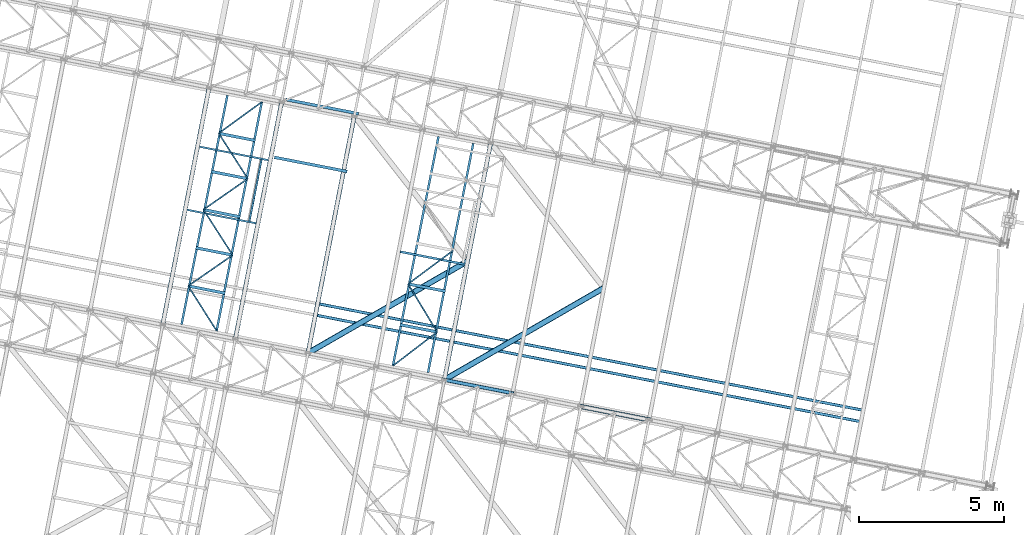
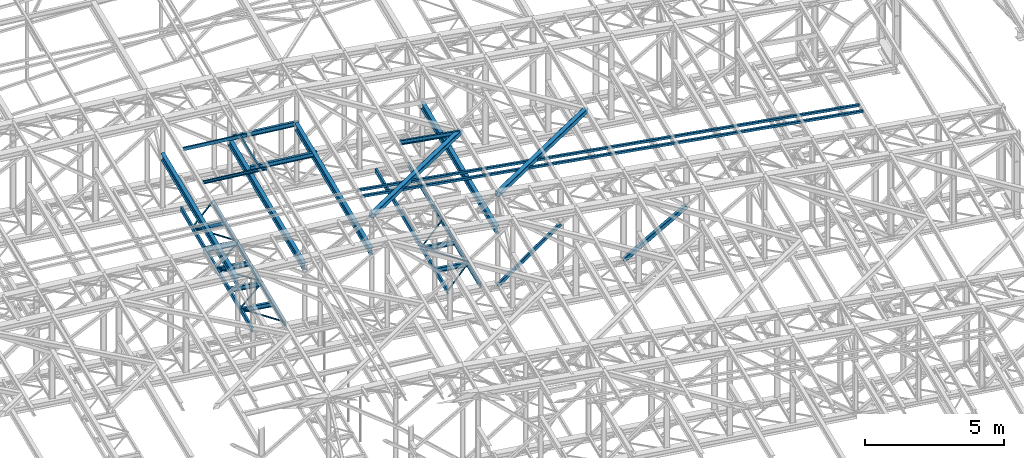
# One storey, part 90 of 215: 34 beams, 2 members, 36 elements without a shape of their own.
"""IFC2X3 building model written with IfcOpenShell, lengths in millimetres."""

from ifc_helpers import new_model, si_unit, frame, origin_with_axes, origin_2d_with_axis, place, context, subcontext, project, spatial, hollow_rectangle, i_section, u_section, extrude, material, type_object, element, aggregate, save


model = new_model("IFC2X3")

# Units and contexts
model_context = context("Model", 3, precision=1e-05, world=origin_with_axes())
body_context = subcontext(model_context, "Body", "Model", "MODEL_VIEW")
ifc_project = project(units=[si_unit("LENGTHUNIT", "METRE", prefix="MILLI"), si_unit("AREAUNIT", "SQUARE_METRE"), si_unit("VOLUMEUNIT", "CUBIC_METRE"), si_unit("MASSUNIT", "GRAM", prefix="KILO"), si_unit("TIMEUNIT", "SECOND"), si_unit("PLANEANGLEUNIT", "RADIAN"), si_unit("SOLIDANGLEUNIT", "STERADIAN"), si_unit("THERMODYNAMICTEMPERATUREUNIT", "DEGREE_CELSIUS"), si_unit("LUMINOUSINTENSITYUNIT", "LUMEN")], contexts=[model_context])

# Site, building, storey
site_placement = place(None, origin_with_axes())
site = spatial("IfcSite", under=ifc_project, at=site_placement, CompositionType="ELEMENT")
building_placement = place(site_placement, origin_with_axes())
building = spatial("IfcBuilding", under=site, at=building_placement, Name="Undefined", CompositionType="ELEMENT")
storey_placement = place(building_placement, origin_with_axes())
storey = spatial("IfcBuildingStorey", under=building, at=storey_placement, Name="Undefined", CompositionType="ELEMENT", Elevation=0.0)

# Assembly, beam
assembly_1_placement = place(storey_placement, origin_with_axes())
assembly_1 = element("IfcElementAssembly", 1, at=assembly_1_placement, inside=storey, Name="Steel Assembly", AssemblyPlace="NOTDEFINED", PredefinedType="RIGID_FRAME")
ifc_material_1 = material(Name="STEEL/S275JR")
beam_type_1 = type_object("IfcBeamType", PredefinedType="NOTDEFINED")
beam_1_placement = place(assembly_1_placement, frame((71760.0971144272, 40485.748409358, 12727.980944659), z_axis=(-0.0304080339975108, 0.00594450399951394, -0.999519891918418), x_axis=(0.980943076639626, -0.191809005929534, -0.0309836349886174)))
beam_1 = element("IfcBeam", 2, at=beam_1_placement, type_object=beam_type_1, material=ifc_material_1, context=body_context, shape_type="SweptSolid", body=[
    extrude(hollow_rectangle(XDim=100.0, YDim=100.0, WallThickness=5.0, InnerFilletRadius=5.0, OuterFilletRadius=10.0, at=origin_2d_with_axis()), frame((19054.6230953848, 6.46745726067925e-12, -1.32218008037815e-13), z_axis=(-1.0, 0.0, 0.0), x_axis=(-6.93889390390723e-18, -1.0, -3.46944695195361e-18)), (0.0, 0.0, 1.0), 19054.6),
])
aggregate(assembly_1, [beam_1])

assembly_2_placement = place(storey_placement, origin_with_axes())
assembly_2 = element("IfcElementAssembly", 3, at=assembly_2_placement, inside=storey, Name="Steel Assembly", AssemblyPlace="NOTDEFINED", PredefinedType="RIGID_FRAME")
beam_2_placement = place(assembly_2_placement, frame((71683.3366470198, 40093.1827070397, 12727.9809445481), z_axis=(-0.0304080339975108, 0.00594450399951394, -0.999519891918418), x_axis=(0.980943076639626, -0.191809005929534, -0.0309836349886174)))
beam_2 = element("IfcBeam", 4, at=beam_2_placement, type_object=beam_type_1, material=ifc_material_1, context=body_context, shape_type="SweptSolid", body=[
    extrude(hollow_rectangle(XDim=100.0, YDim=100.0, WallThickness=5.0, InnerFilletRadius=5.0, OuterFilletRadius=10.0, at=origin_2d_with_axis()), frame((19054.6230953848, 6.46745726067925e-12, -1.32218008037815e-13), z_axis=(-1.0, 0.0, 0.0), x_axis=(-6.93889390390723e-18, -1.0, -3.46944695195361e-18)), (0.0, 0.0, 1.0), 19054.6),
])
aggregate(assembly_2, [beam_2])

assembly_3_placement = place(storey_placement, origin_with_axes())
assembly_3 = element("IfcElementAssembly", 5, at=assembly_3_placement, inside=storey, Name="Steel Assembly", AssemblyPlace="NOTDEFINED", PredefinedType="RIGID_FRAME")
beam_type_2 = type_object("IfcBeamType", PredefinedType="NOTDEFINED")
beam_3_placement = place(assembly_3_placement, frame((75811.4755833182, 39522.2912001159, 8745.0), z_axis=(0.0, 0.0, -1.0), x_axis=(-0.79408618805292, -0.607805171040509, 0.0)))
beam_3 = element("IfcBeam", 6, at=beam_3_placement, type_object=beam_type_2, material=ifc_material_1, context=body_context, shape_type="SweptSolid", body=[
    extrude(hollow_rectangle(XDim=50.0, YDim=50.0, WallThickness=3.0, InnerFilletRadius=3.0, OuterFilletRadius=6.0, at=origin_2d_with_axis()), frame((1907.07835374003, -1.05864114904321e-13, 0.0), z_axis=(-1.0, 0.0, 0.0), x_axis=(-6.93889390390723e-18, -1.0, -3.46944695195361e-18)), (0.0, 0.0, 1.0), 1907.1),
])
aggregate(assembly_3, [beam_3])

assembly_4_placement = place(storey_placement, origin_with_axes())
assembly_4 = element("IfcElementAssembly", 7, at=assembly_4_placement, inside=storey, Name="Steel Assembly", AssemblyPlace="NOTDEFINED", PredefinedType="RIGID_FRAME")
beam_4_placement = place(assembly_4_placement, frame((67254.4397263109, 41103.1133654688, 8745.0), z_axis=(0.0, 0.0, -1.0), x_axis=(0.535514965031223, -0.844525738049237, 0.0)))
beam_4 = element("IfcBeam", 8, at=beam_4_placement, type_object=beam_type_2, material=ifc_material_1, context=body_context, shape_type="SweptSolid", body=[
    extrude(hollow_rectangle(XDim=50.0, YDim=50.0, WallThickness=3.0, InnerFilletRadius=3.0, OuterFilletRadius=6.0, at=origin_2d_with_axis()), frame((1826.34846929784, 0.0, 0.0), z_axis=(-1.0, 0.0, 0.0), x_axis=(-6.93889390390723e-18, -1.0, -3.46944695195361e-18)), (0.0, 0.0, 1.0), 1826.3),
])
aggregate(assembly_4, [beam_4])

assembly_5_placement = place(storey_placement, origin_with_axes())
assembly_5 = element("IfcElementAssembly", 9, at=assembly_5_placement, inside=storey, Name="Steel Assembly", AssemblyPlace="NOTDEFINED", PredefinedType="RIGID_FRAME")
beam_5_placement = place(assembly_5_placement, frame((68784.1157093608, 42163.947772799, 8745.0), z_axis=(0.0, 0.0, -1.0), x_axis=(-0.82173236308309, -0.569873603057627, 0.0)))
beam_5 = element("IfcBeam", 10, at=beam_5_placement, type_object=beam_type_2, material=ifc_material_1, context=body_context, shape_type="SweptSolid", body=[
    extrude(hollow_rectangle(XDim=50.0, YDim=50.0, WallThickness=3.0, InnerFilletRadius=3.0, OuterFilletRadius=6.0, at=origin_2d_with_axis()), frame((1861.52578629915, -9.09494701772928e-13, 1.81898940354586e-12), z_axis=(-1.0, 0.0, 0.0), x_axis=(-6.93889390390723e-18, -1.0, -3.46944695195361e-18)), (0.0, 0.0, 1.0), 1861.5),
])
aggregate(assembly_5, [beam_5])

assembly_6_placement = place(storey_placement, origin_with_axes())
assembly_6 = element("IfcElementAssembly", 11, at=assembly_6_placement, inside=storey, Name="Steel Assembly", AssemblyPlace="NOTDEFINED", PredefinedType="RIGID_FRAME")
beam_6_placement = place(assembly_6_placement, frame((67779.1252784638, 43726.6375422795, 8745.0), z_axis=(0.0, 0.0, -1.0), x_axis=(0.540911498210623, -0.841079515327498, 0.0)))
beam_6 = element("IfcBeam", 12, at=beam_6_placement, type_object=beam_type_2, material=ifc_material_1, context=body_context, shape_type="SweptSolid", body=[
    extrude(hollow_rectangle(XDim=50.0, YDim=50.0, WallThickness=3.0, InnerFilletRadius=3.0, OuterFilletRadius=6.0, at=origin_2d_with_axis()), frame((1857.95723370648, -1.0313734498149e-13, 0.0), z_axis=(-1.0, 0.0, 0.0), x_axis=(-6.93889390390723e-18, -1.0, -3.46944695195361e-18)), (0.0, 0.0, 1.0), 1858.0),
])
aggregate(assembly_6, [beam_6])

assembly_7_placement = place(storey_placement, origin_with_axes())
assembly_7 = element("IfcElementAssembly", 13, at=assembly_7_placement, inside=storey, Name="Steel Assembly", AssemblyPlace="NOTDEFINED", PredefinedType="RIGID_FRAME")
beam_7_placement = place(assembly_7_placement, frame((69303.2921745748, 44788.5637698826, 8745.0), z_axis=(0.0, 0.0, -1.0), x_axis=(-0.820492073033562, -0.57165790302338, 0.0)))
beam_7 = element("IfcBeam", 14, at=beam_7_placement, type_object=beam_type_2, material=ifc_material_1, context=body_context, shape_type="SweptSolid", body=[
    extrude(hollow_rectangle(XDim=50.0, YDim=50.0, WallThickness=3.0, InnerFilletRadius=3.0, OuterFilletRadius=6.0, at=origin_2d_with_axis()), frame((1857.62537670751, -1.03118923217433e-13, 0.0), z_axis=(-1.0, 0.0, 0.0), x_axis=(-6.93889390390723e-18, -1.0, -3.46944695195361e-18)), (0.0, 0.0, 1.0), 1857.6),
])
aggregate(assembly_7, [beam_7])

assembly_8_placement = place(storey_placement, origin_with_axes())
assembly_8 = element("IfcElementAssembly", 15, at=assembly_8_placement, inside=storey, Name="Steel Assembly", AssemblyPlace="NOTDEFINED", PredefinedType="RIGID_FRAME")
beam_8_placement = place(assembly_8_placement, frame((68303.8108306167, 46350.1617190901, 8745.0), z_axis=(0.0, 0.0, -1.0), x_axis=(0.539076140159352, -0.842257036248968, 0.0)))
beam_8 = element("IfcBeam", 16, at=beam_8_placement, type_object=beam_type_2, material=ifc_material_1, context=body_context, shape_type="SweptSolid", body=[
    extrude(hollow_rectangle(XDim=50.0, YDim=50.0, WallThickness=3.0, InnerFilletRadius=3.0, OuterFilletRadius=6.0, at=origin_2d_with_axis()), frame((1854.06340553235, 0.0, 0.0), z_axis=(-1.0, 0.0, 0.0), x_axis=(-6.93889390390723e-18, -1.0, -3.46944695195361e-18)), (0.0, 0.0, 1.0), 1854.1),
])
aggregate(assembly_8, [beam_8])

assembly_9_placement = place(storey_placement, origin_with_axes())
assembly_9 = element("IfcElementAssembly", 17, at=assembly_9_placement, inside=storey, Name="Steel Assembly", AssemblyPlace="NOTDEFINED", PredefinedType="RIGID_FRAME")
beam_9_placement = place(assembly_9_placement, frame((69782.1158846942, 47424.3089371193, 8745.0), z_axis=(0.0, 0.0, -1.0), x_axis=(-0.808992082681723, -0.587819538768735, 0.0)))
beam_9 = element("IfcBeam", 18, at=beam_9_placement, type_object=beam_type_2, material=ifc_material_1, context=body_context, shape_type="SweptSolid", body=[
    extrude(hollow_rectangle(XDim=50.0, YDim=50.0, WallThickness=3.0, InnerFilletRadius=3.0, OuterFilletRadius=6.0, at=origin_2d_with_axis()), frame((1827.34180674125, 0.0, 0.0), z_axis=(-1.0, 0.0, 0.0), x_axis=(-6.93889390390723e-18, -1.0, -3.46944695195361e-18)), (0.0, 0.0, 1.0), 1827.3),
])
aggregate(assembly_9, [beam_9])

assembly_10_placement = place(storey_placement, origin_with_axes())
assembly_10 = element("IfcElementAssembly", 19, at=assembly_10_placement, inside=storey, Name="Steel Assembly", AssemblyPlace="NOTDEFINED", PredefinedType="RIGID_FRAME")
beam_10_placement = place(assembly_10_placement, frame((74812.6471326999, 41172.5850104912, 8745.0), z_axis=(0.0, 0.0, -1.0), x_axis=(0.517808927242957, -0.855496297401396, 0.0)))
beam_10 = element("IfcBeam", 20, at=beam_10_placement, type_object=beam_type_2, material=ifc_material_1, context=body_context, shape_type="SweptSolid", body=[
    extrude(hollow_rectangle(XDim=50.0, YDim=50.0, WallThickness=3.0, InnerFilletRadius=3.0, OuterFilletRadius=6.0, at=origin_2d_with_axis()), frame((1929.07382191218, 0.0, 0.0), z_axis=(-1.0, 0.0, 0.0), x_axis=(-6.93889390390723e-18, -1.0, -3.46944695195361e-18)), (0.0, 0.0, 1.0), 1929.1),
])
aggregate(assembly_10, [beam_10])

assembly_11_placement = place(storey_placement, origin_with_axes())
assembly_11 = element("IfcElementAssembly", 21, at=assembly_11_placement, inside=storey, Name="Steel Assembly", AssemblyPlace="NOTDEFINED", PredefinedType="RIGID_FRAME")
beam_11_placement = place(assembly_11_placement, frame((76365.2607052692, 42324.1190063825, 8745.0), z_axis=(0.0, 0.0, -1.0), x_axis=(-0.803198301073351, -0.595711750054406, 0.0)))
beam_11 = element("IfcBeam", 22, at=beam_11_placement, type_object=beam_type_2, material=ifc_material_1, context=body_context, shape_type="SweptSolid", body=[
    extrude(hollow_rectangle(XDim=50.0, YDim=50.0, WallThickness=3.0, InnerFilletRadius=3.0, OuterFilletRadius=6.0, at=origin_2d_with_axis()), frame((1933.03891586361, -2.14610431188823e-13, 0.0), z_axis=(-1.0, 0.0, 0.0), x_axis=(-6.93889390390723e-18, -1.0, -3.46944695195361e-18)), (0.0, 0.0, 1.0), 1933.0),
])
aggregate(assembly_11, [beam_11])

assembly_12_placement = place(storey_placement, origin_with_axes())
assembly_12 = element("IfcElementAssembly", 23, at=assembly_12_placement, inside=storey, Name="Steel Assembly", AssemblyPlace="NOTDEFINED", PredefinedType="RIGID_FRAME")
ifc_material_2 = material(Name="STEEL/S235JR")
beam_type_3 = type_object("IfcBeamType", Name="UPN140", PredefinedType="NOTDEFINED")
beam_12_placement = place(assembly_12_placement, frame((69359.8557503817, 43332.3585434962, 12761.5566364276), z_axis=(-0.0304080349967745, 0.00594450299936818, 0.999519891893966), x_axis=(0.191880718074391, 0.981418254380493, 4.40000000352173e-08)))
beam_12 = element("IfcBeam", 24, at=beam_12_placement, type_object=beam_type_3, material=ifc_material_2, ObjectType="UPN140", context=body_context, shape_type="SweptSolid", body=[
    extrude(u_section(Depth=140.0, FlangeWidth=60.0, WebThickness=7.0, FlangeThickness=10.0, FilletRadius=10.0, EdgeRadius=5.0, FlangeSlope=0.0798299857122373, at=origin_2d_with_axis()), frame((2149.99964798419, 2.35154323650116e-15, 1.8176342764527e-12), z_axis=(-1.0, 0.0, 0.0), x_axis=(-6.93889390390723e-18, -1.0, -3.46944695195361e-18)), (0.0, 0.0, 1.0), 2150.0),
])
aggregate(assembly_12, [beam_12])

assembly_13_placement = place(storey_placement, origin_with_axes())
assembly_13 = element("IfcElementAssembly", 25, at=assembly_13_placement, inside=storey, Name="Steel Assembly", AssemblyPlace="NOTDEFINED", PredefinedType="RIGID_FRAME")
beam_13_placement = place(assembly_13_placement, frame((70018.1932395436, 45424.9236830966, 12769.1384012091), z_axis=(-0.0304080349967745, 0.00594450299936818, 0.999519891893966), x_axis=(-0.980947279001733, 0.191787511000338, -0.0309836480000548)))
beam_13 = element("IfcBeam", 26, at=beam_13_placement, type_object=beam_type_3, material=ifc_material_2, ObjectType="UPN140", context=body_context, shape_type="SweptSolid", body=[
    extrude(u_section(Depth=140.0, FlangeWidth=60.0, WebThickness=7.0, FlangeThickness=10.0, FilletRadius=10.0, EdgeRadius=5.0, FlangeSlope=0.0798299857122373, at=origin_2d_with_axis()), frame((2424.69780127148, -3.7379625959944e-14, 0.0), z_axis=(-1.0, 0.0, 0.0), x_axis=(-6.93889390390723e-18, -1.0, -3.46944695195361e-18)), (0.0, 0.0, 1.0), 2424.7),
])
aggregate(assembly_13, [beam_13])

assembly_14_placement = place(storey_placement, origin_with_axes())
assembly_14 = element("IfcElementAssembly", 27, at=assembly_14_placement, inside=storey, Name="Steel Assembly", AssemblyPlace="NOTDEFINED", PredefinedType="RIGID_FRAME")
beam_14_placement = place(assembly_14_placement, frame((67215.6361783717, 43721.015713209, 12694.0123238782), z_axis=(-0.0304080349967745, 0.00594450299936818, 0.999519891893966), x_axis=(0.9809472788136, -0.191787511963556, 0.0309836479941128)))
beam_14 = element("IfcBeam", 28, at=beam_14_placement, type_object=beam_type_3, material=ifc_material_2, ObjectType="UPN140", context=body_context, shape_type="SweptSolid", body=[
    extrude(u_section(Depth=140.0, FlangeWidth=60.0, WebThickness=7.0, FlangeThickness=10.0, FilletRadius=10.0, EdgeRadius=5.0, FlangeSlope=0.0798299857122373, at=origin_2d_with_axis()), frame((2424.69780127148, -3.7379625959944e-14, 0.0), z_axis=(-1.0, 0.0, 0.0), x_axis=(-6.93889390390723e-18, -1.0, -3.46944695195361e-18)), (0.0, 0.0, 1.0), 2424.7),
])
aggregate(assembly_14, [beam_14])

assembly_15_placement = place(storey_placement, origin_with_axes())
assembly_15 = element("IfcElementAssembly", 29, at=assembly_15_placement, inside=storey, Name="Steel Assembly", AssemblyPlace="NOTDEFINED", PredefinedType="RIGID_FRAME")
beam_type_4 = type_object("IfcBeamType", Name="UPN200", PredefinedType="NOTDEFINED")
beam_15_placement = place(assembly_15_placement, frame((74545.5207751963, 42280.4389818279, 12743.959350756), z_axis=(0.0304080349965938, -0.00594450399933318, 0.999519891888024), x_axis=(0.980947274706054, -0.191787533942531, -0.0309836419907153)))
beam_15 = element("IfcBeam", 30, at=beam_15_placement, type_object=beam_type_4, material=ifc_material_2, ObjectType="UPN200", context=body_context, shape_type="SweptSolid", body=[
    extrude(u_section(Depth=200.0, FlangeWidth=75.0, WebThickness=8.5, FlangeThickness=11.5, FilletRadius=11.5, EdgeRadius=6.0, FlangeSlope=0.0798299857122373, at=origin_2d_with_axis()), frame((2269.56619159897, -1.00164711038344e-14, -7.87413950570001e-15), z_axis=(-1.0, 0.0, 0.0), x_axis=(-6.93889390390723e-18, -1.0, -3.46944695195361e-18)), (0.0, 0.0, 1.0), 2269.6),
])
aggregate(assembly_15, [beam_15])

assembly_16_placement = place(storey_placement, origin_with_axes())
assembly_16 = element("IfcElementAssembly", 31, at=assembly_16_placement, inside=storey, Name="Steel Assembly", AssemblyPlace="NOTDEFINED", PredefinedType="RIGID_FRAME")
beam_16_placement = place(assembly_16_placement, frame((68602.925434007, 47654.5697123101, 8670.00000003361), z_axis=(0.0, 0.0, -1.0), x_axis=(-0.196109204940981, -0.980582061704892, 0.0)))
beam_16 = element("IfcBeam", 32, at=beam_16_placement, type_object=beam_type_4, material=ifc_material_1, ObjectType="UPN200", context=body_context, shape_type="SweptSolid", body=[
    extrude(u_section(Depth=200.0, FlangeWidth=75.0, WebThickness=8.5, FlangeThickness=11.5, FilletRadius=11.5, EdgeRadius=6.0, FlangeSlope=0.0798299857122373, at=origin_2d_with_axis()), frame((8026.42923811888, 0.0, 1.81898940354586e-12), z_axis=(-1.0, 0.0, 0.0), x_axis=(-6.93889390390723e-18, -1.0, -3.46944695195361e-18)), (0.0, 0.0, 1.0), 8026.4),
])
aggregate(assembly_16, [beam_16])

assembly_17_placement = place(storey_placement, origin_with_axes())
assembly_17 = element("IfcElementAssembly", 33, at=assembly_17_placement, inside=storey, Name="Steel Assembly", AssemblyPlace="NOTDEFINED", PredefinedType="RIGID_FRAME")
beam_17_placement = place(assembly_17_placement, frame((68228.7504539045, 39549.6817770893, 8670.00000000005), z_axis=(0.0, 0.0, -1.0), x_axis=(0.194052090085154, 0.980991226430483, 0.0)))
beam_17 = element("IfcBeam", 34, at=beam_17_placement, type_object=beam_type_4, material=ifc_material_1, ObjectType="UPN200", context=body_context, shape_type="SweptSolid", body=[
    extrude(u_section(Depth=200.0, FlangeWidth=75.0, WebThickness=8.5, FlangeThickness=11.5, FilletRadius=11.5, EdgeRadius=6.0, FlangeSlope=0.0798299857122373, at=origin_2d_with_axis()), frame((8026.37396392401, 4.45553258950016e-13, 0.0), z_axis=(-1.0, 0.0, 0.0), x_axis=(-6.93889390390723e-18, -1.0, -3.46944695195361e-18)), (0.0, 0.0, 1.0), 8026.4),
])
aggregate(assembly_17, [beam_17])

assembly_18_placement = place(storey_placement, origin_with_axes())
assembly_18 = element("IfcElementAssembly", 35, at=assembly_18_placement, inside=storey, Name="Steel Assembly", AssemblyPlace="NOTDEFINED", PredefinedType="RIGID_FRAME")
beam_18_placement = place(assembly_18_placement, frame((75856.9384994889, 46236.522651763, 8670.00000003361), z_axis=(0.0, 0.0, -1.0), x_axis=(-0.194859176941111, -0.980831229703578, 0.0)))
beam_18 = element("IfcBeam", 36, at=beam_18_placement, type_object=beam_type_4, material=ifc_material_1, ObjectType="UPN200", context=body_context, shape_type="SweptSolid", body=[
    extrude(u_section(Depth=200.0, FlangeWidth=75.0, WebThickness=8.5, FlangeThickness=11.5, FilletRadius=11.5, EdgeRadius=6.0, FlangeSlope=0.0798299857122373, at=origin_2d_with_axis()), frame((8026.39143846781, 0.0, 0.0), z_axis=(-1.0, 0.0, 0.0), x_axis=(-6.93889390390723e-18, -1.0, -3.46944695195361e-18)), (0.0, 0.0, 1.0), 8026.4),
])
aggregate(assembly_18, [beam_18])

assembly_19_placement = place(storey_placement, origin_with_axes())
assembly_19 = element("IfcElementAssembly", 37, at=assembly_19_placement, inside=storey, Name="Steel Assembly", AssemblyPlace="NOTDEFINED", PredefinedType="RIGID_FRAME")
beam_19_placement = place(assembly_19_placement, frame((75498.090298128, 38128.5774915551, 8670.00000000005), z_axis=(0.0, 0.0, -1.0), x_axis=(0.193737014918304, 0.981053499586309, 0.0)))
beam_19 = element("IfcBeam", 38, at=beam_19_placement, type_object=beam_type_4, material=ifc_material_1, ObjectType="UPN200", context=body_context, shape_type="SweptSolid", body=[
    extrude(u_section(Depth=200.0, FlangeWidth=75.0, WebThickness=8.5, FlangeThickness=11.5, FilletRadius=11.5, EdgeRadius=6.0, FlangeSlope=0.0798299857122373, at=origin_2d_with_axis()), frame((8026.36861737095, 2.2277648107835e-13, 0.0), z_axis=(-1.0, 0.0, 0.0), x_axis=(-6.93889390390723e-18, -1.0, -3.46944695195361e-18)), (0.0, 0.0, 1.0), 8026.4),
])
aggregate(assembly_19, [beam_19])

# Assembly, member
assembly_20_placement = place(storey_placement, origin_with_axes())
assembly_20 = element("IfcElementAssembly", 39, at=assembly_20_placement, inside=storey, Name="Steel Assembly", AssemblyPlace="NOTDEFINED", PredefinedType="RIGID_FRAME")
member_type_1 = type_object("IfcMemberType", PredefinedType="NOTDEFINED")
member_1_placement = place(assembly_20_placement, frame((76059.9648931922, 37875.3654009255, 8635.00000002286), z_axis=(0.658795867060445, -0.12879937101182, -0.741214360068014), x_axis=(0.727444441074387, -0.142208697014541, 0.671268405068643)))
member_1 = element("IfcMember", 40, at=member_1_placement, type_object=member_type_1, material=ifc_material_1, context=body_context, shape_type="SweptSolid", body=[
    extrude(hollow_rectangle(XDim=120.0, YDim=120.0, WallThickness=5.0, InnerFilletRadius=5.0, OuterFilletRadius=10.0, at=origin_2d_with_axis()), frame((3220.54913749736, 7.11337137710058e-12, -7.63351039462205e-12), z_axis=(-1.0, 0.0, 0.0), x_axis=(-6.93889390390723e-18, -1.0, -3.46944695195361e-18)), (0.0, 0.0, 1.0), 3220.5),
])
aggregate(assembly_20, [member_1])

# Assembly, beam
assembly_21_placement = place(storey_placement, origin_with_axes())
assembly_21 = element("IfcElementAssembly", 41, at=assembly_21_placement, inside=storey, Name="Steel Assembly", AssemblyPlace="NOTDEFINED", PredefinedType="RIGID_FRAME")
beam_type_5 = type_object("IfcBeamType", PredefinedType="NOTDEFINED")
beam_20_placement = place(assembly_21_placement, frame((76852.8912811883, 41952.7962116705, 12636.7951372244), z_axis=(0.0304080349965938, -0.00594450399933318, 0.999519891888024), x_axis=(-0.866283444084822, -0.49900505904886, 0.0233868670022899)))
beam_20 = element("IfcBeam", 42, at=beam_20_placement, type_object=beam_type_5, material=ifc_material_1, context=body_context, shape_type="SweptSolid", body=[
    extrude(hollow_rectangle(XDim=200.0, YDim=200.0, WallThickness=10.0, InnerFilletRadius=15.0, OuterFilletRadius=25.0, at=origin_2d_with_axis()), frame((6331.64739830774, 4.27929973367209e-13, 0.0), z_axis=(-1.0, 0.0, 0.0), x_axis=(-6.93889390390723e-18, -1.0, -3.46944695195361e-18)), (0.0, 0.0, 1.0), 6331.6),
])
aggregate(assembly_21, [beam_20])

assembly_22_placement = place(storey_placement, origin_with_axes())
assembly_22 = element("IfcElementAssembly", 43, at=assembly_22_placement, inside=storey, Name="Steel Assembly", AssemblyPlace="NOTDEFINED", PredefinedType="RIGID_FRAME")
beam_21_placement = place(assembly_22_placement, frame((81540.9870159243, 41036.314593356, 12488.7202382545), z_axis=(0.0304080349965938, -0.00594450399933318, 0.999519891888024), x_axis=(-0.866283444084822, -0.49900505904886, 0.0233868670022899)))
beam_21 = element("IfcBeam", 44, at=beam_21_placement, type_object=beam_type_5, material=ifc_material_1, context=body_context, shape_type="SweptSolid", body=[
    extrude(hollow_rectangle(XDim=200.0, YDim=200.0, WallThickness=10.0, InnerFilletRadius=15.0, OuterFilletRadius=25.0, at=origin_2d_with_axis()), frame((6331.64739830774, 4.27929973367209e-13, 0.0), z_axis=(-1.0, 0.0, 0.0), x_axis=(-6.93889390390723e-18, -1.0, -3.46944695195361e-18)), (0.0, 0.0, 1.0), 6331.6),
])
aggregate(assembly_22, [beam_21])

assembly_23_placement = place(storey_placement, origin_with_axes())
assembly_23 = element("IfcElementAssembly", 45, at=assembly_23_placement, inside=storey, Name="Steel Assembly", AssemblyPlace="NOTDEFINED", PredefinedType="RIGID_FRAME")
beam_type_6 = type_object("IfcBeamType", Name="IPE300", PredefinedType="NOTDEFINED")
beam_22_placement = place(assembly_23_placement, frame((76060.0918401987, 37875.987944362, 11049.7700001321), z_axis=(0.0, 0.0, 1.0), x_axis=(0.191879342079262, 0.981418523405397, 1.00000006478113e-09)))
beam_22 = element("IfcBeam", 46, at=beam_22_placement, type_object=beam_type_6, material=ifc_material_1, Name="SUPPORT", ObjectType="IPE300", context=body_context, shape_type="SweptSolid", body=[
    extrude(i_section(OverallWidth=150.0, OverallDepth=300.0, WebThickness=7.099999905, FlangeThickness=10.69999981, FilletRadius=15.0, at=origin_2d_with_axis()), frame((8306.35394615426, -2.30547635042662e-13, -1.81898940354586e-12), z_axis=(-1.0, 0.0, 0.0), x_axis=(-6.93889390390723e-18, -1.0, -3.46944695195361e-18)), (0.0, 0.0, 1.0), 8306.4),
])
aggregate(assembly_23, [beam_22])

assembly_24_placement = place(storey_placement, origin_with_axes())
assembly_24 = element("IfcElementAssembly", 47, at=assembly_24_placement, inside=storey, Name="Steel Assembly", AssemblyPlace="NOTDEFINED", PredefinedType="RIGID_FRAME")
beam_23_placement = place(assembly_24_placement, frame((71371.9960795841, 38792.4694380855, 11197.7200001516), z_axis=(0.0, 0.0, 1.0), x_axis=(0.191879342079262, 0.981418523405397, 1.00000006478113e-09)))
beam_23 = element("IfcBeam", 48, at=beam_23_placement, type_object=beam_type_6, material=ifc_material_1, Name="SUPPORT", ObjectType="IPE300", context=body_context, shape_type="SweptSolid", body=[
    extrude(i_section(OverallWidth=150.0, OverallDepth=300.0, WebThickness=7.099999905, FlangeThickness=10.69999981, FilletRadius=15.0, at=origin_2d_with_axis()), frame((8306.35394615426, -2.30547635042662e-13, -1.81898940354586e-12), z_axis=(-1.0, 0.0, 0.0), x_axis=(-6.93889390390723e-18, -1.0, -3.46944695195361e-18)), (0.0, 0.0, 1.0), 8306.4),
])
aggregate(assembly_24, [beam_23])

assembly_25_placement = place(storey_placement, origin_with_axes())
assembly_25 = element("IfcElementAssembly", 49, at=assembly_25_placement, inside=storey, Name="Steel Assembly", AssemblyPlace="NOTDEFINED", PredefinedType="RIGID_FRAME")
beam_24_placement = place(assembly_25_placement, frame((68875.7719751619, 39280.4592985122, 11119.0000001701), z_axis=(0.0, 0.0, 1.0), x_axis=(0.191879342079262, 0.981418523405397, 1.00000006478113e-09)))
beam_24 = element("IfcBeam", 50, at=beam_24_placement, type_object=beam_type_6, material=ifc_material_1, Name="SUPPORT", ObjectType="IPE300", context=body_context, shape_type="SweptSolid", body=[
    extrude(i_section(OverallWidth=150.0, OverallDepth=300.0, WebThickness=7.099999905, FlangeThickness=10.69999981, FilletRadius=15.0, at=origin_2d_with_axis()), frame((8306.35394615426, -2.30547635042662e-13, -1.81898940354586e-12), z_axis=(-1.0, 0.0, 0.0), x_axis=(-6.93889390390723e-18, -1.0, -3.46944695195361e-18)), (0.0, 0.0, 1.0), 8306.4),
])
aggregate(assembly_25, [beam_24])

assembly_26_placement = place(storey_placement, origin_with_axes())
assembly_26 = element("IfcElementAssembly", 51, at=assembly_26_placement, inside=storey, Name="Steel Assembly", AssemblyPlace="NOTDEFINED", PredefinedType="RIGID_FRAME")
beam_25_placement = place(assembly_26_placement, frame((66379.5478681464, 39768.4491594459, 11040.1600001886), z_axis=(0.0, 0.0, 1.0), x_axis=(0.191879342079262, 0.981418523405397, 1.00000006478113e-09)))
beam_25 = element("IfcBeam", 52, at=beam_25_placement, type_object=beam_type_6, material=ifc_material_1, Name="SUPPORT", ObjectType="IPE300", context=body_context, shape_type="SweptSolid", body=[
    extrude(i_section(OverallWidth=150.0, OverallDepth=300.0, WebThickness=7.099999905, FlangeThickness=10.69999981, FilletRadius=15.0, at=origin_2d_with_axis()), frame((8306.35394615426, -2.30547635042662e-13, -1.81898940354586e-12), z_axis=(-1.0, 0.0, 0.0), x_axis=(-6.93889390390723e-18, -1.0, -3.46944695195361e-18)), (0.0, 0.0, 1.0), 8306.4),
])
aggregate(assembly_26, [beam_25])

assembly_27_placement = place(storey_placement, origin_with_axes())
assembly_27 = element("IfcElementAssembly", 53, at=assembly_27_placement, inside=storey, Name="Steel Assembly", AssemblyPlace="NOTDEFINED", PredefinedType="RIGID_FRAME")
beam_type_7 = type_object("IfcBeamType", Name="IPE200", PredefinedType="NOTDEFINED")
beam_26_placement = place(assembly_27_placement, frame((68784.1157093608, 42163.947772799, 8670.00000000005), z_axis=(0.0, 0.0, -1.0), x_axis=(-0.98095678532404, 0.194226119064161, 0.0)))
beam_26 = element("IfcBeam", 54, at=beam_26_placement, type_object=beam_type_7, material=ifc_material_1, ObjectType="IPE200", context=body_context, shape_type="SweptSolid", body=[
    extrude(i_section(OverallWidth=100.0, OverallDepth=200.0, WebThickness=5.599999905, FlangeThickness=8.5, FilletRadius=12.0, at=origin_2d_with_axis()), frame((1291.93581828606, 0.0, 0.0), z_axis=(-1.0, 0.0, 0.0), x_axis=(-6.93889390390723e-18, -1.0, -3.46944695195361e-18)), (0.0, 0.0, 1.0), 1291.9),
])
aggregate(assembly_27, [beam_26])

assembly_28_placement = place(storey_placement, origin_with_axes())
assembly_28 = element("IfcElementAssembly", 55, at=assembly_28_placement, inside=storey, Name="Steel Assembly", AssemblyPlace="NOTDEFINED", PredefinedType="RIGID_FRAME")
beam_27_placement = place(assembly_28_placement, frame((70611.8324304934, 47511.0672332461, 11169.0478651314), z_axis=(0.0303605499861654, -0.00593522099729565, -0.99952139054462), x_axis=(0.980952689077156, -0.191767651015084, 0.030935252002433)))
beam_27 = element("IfcBeam", 56, at=beam_27_placement, type_object=beam_type_7, material=ifc_material_1, ObjectType="IPE200", context=body_context, shape_type="SweptSolid", body=[
    extrude(i_section(OverallWidth=100.0, OverallDepth=200.0, WebThickness=5.599999905, FlangeThickness=8.5, FilletRadius=12.0, at=origin_2d_with_axis()), frame((2544.66727454958, 2.95700928513306e-14, 1.81016081542643e-12), z_axis=(-1.0, 0.0, 0.0), x_axis=(-6.93889390390723e-18, -1.0, -3.46944695195361e-18)), (0.0, 0.0, 1.0), 2544.7),
])
aggregate(assembly_28, [beam_27])

assembly_29_placement = place(storey_placement, origin_with_axes())
assembly_29 = element("IfcElementAssembly", 57, at=assembly_29_placement, inside=storey, Name="Steel Assembly", AssemblyPlace="NOTDEFINED", PredefinedType="RIGID_FRAME")
beam_28_placement = place(assembly_29_placement, frame((70219.3899376849, 45524.4615520781, 11169.0478651285), z_axis=(0.0303605499861654, -0.00593522099729565, -0.99952139054462), x_axis=(0.980952689077156, -0.191767651015084, 0.030935252002433)))
beam_28 = element("IfcBeam", 58, at=beam_28_placement, type_object=beam_type_7, material=ifc_material_1, ObjectType="IPE200", context=body_context, shape_type="SweptSolid", body=[
    extrude(i_section(OverallWidth=100.0, OverallDepth=200.0, WebThickness=5.599999905, FlangeThickness=8.5, FilletRadius=12.0, at=origin_2d_with_axis()), frame((2544.66727454958, 2.95700928513306e-14, 1.81016081542643e-12), z_axis=(-1.0, 0.0, 0.0), x_axis=(-6.93889390390723e-18, -1.0, -3.46944695195361e-18)), (0.0, 0.0, 1.0), 2544.7),
])
aggregate(assembly_29, [beam_28])

assembly_30_placement = place(storey_placement, origin_with_axes())
assembly_30 = element("IfcElementAssembly", 59, at=assembly_30_placement, inside=storey, Name="Steel Assembly", AssemblyPlace="NOTDEFINED", PredefinedType="RIGID_FRAME")
beam_29_placement = place(assembly_30_placement, frame((68524.5273186894, 40851.6408331959, 8670.00000000005), z_axis=(0.0, 0.0, -1.0), x_axis=(-0.98095678532404, 0.194226119064161, 0.0)))
beam_29 = element("IfcBeam", 60, at=beam_29_placement, type_object=beam_type_7, material=ifc_material_1, ObjectType="IPE200", context=body_context, shape_type="SweptSolid", body=[
    extrude(i_section(OverallWidth=100.0, OverallDepth=200.0, WebThickness=5.599999905, FlangeThickness=8.5, FilletRadius=12.0, at=origin_2d_with_axis()), frame((1294.74357569135, -7.31189396740138e-12, -1.81898940354586e-12), z_axis=(-1.0, 0.0, 0.0), x_axis=(-6.93889390390723e-18, -1.0, -3.46944695195361e-18)), (0.0, 0.0, 1.0), 1294.7),
])
aggregate(assembly_30, [beam_29])

assembly_31_placement = place(storey_placement, origin_with_axes())
assembly_31 = element("IfcElementAssembly", 61, at=assembly_31_placement, inside=storey, Name="Steel Assembly", AssemblyPlace="NOTDEFINED", PredefinedType="RIGID_FRAME")
beam_30_placement = place(assembly_31_placement, frame((69043.7060333024, 43476.2543299776, 8670.00000000005), z_axis=(0.0, 0.0, -1.0), x_axis=(-0.98095678532404, 0.194226119064161, 0.0)))
beam_30 = element("IfcBeam", 62, at=beam_30_placement, type_object=beam_type_7, material=ifc_material_1, ObjectType="IPE200", context=body_context, shape_type="SweptSolid", body=[
    extrude(i_section(OverallWidth=100.0, OverallDepth=200.0, WebThickness=5.599999905, FlangeThickness=8.5, FilletRadius=12.0, at=origin_2d_with_axis()), frame((1289.13003161773, 0.0, -1.81898940354586e-12), z_axis=(-1.0, 0.0, 0.0), x_axis=(-6.93889390390723e-18, -1.0, -3.46944695195361e-18)), (0.0, 0.0, 1.0), 1289.1),
])
aggregate(assembly_31, [beam_30])

assembly_32_placement = place(storey_placement, origin_with_axes())
assembly_32 = element("IfcElementAssembly", 63, at=assembly_32_placement, inside=storey, Name="Steel Assembly", AssemblyPlace="NOTDEFINED", PredefinedType="RIGID_FRAME")
beam_31_placement = place(assembly_32_placement, frame((69303.298852859, 44788.5603934929, 8670.00000000005), z_axis=(0.0, 0.0, -1.0), x_axis=(-0.98095678532404, 0.194226119064161, 0.0)))
beam_31 = element("IfcBeam", 64, at=beam_31_placement, type_object=beam_type_7, material=ifc_material_1, ObjectType="IPE200", context=body_context, shape_type="SweptSolid", body=[
    extrude(i_section(OverallWidth=100.0, OverallDepth=200.0, WebThickness=5.599999905, FlangeThickness=8.5, FilletRadius=12.0, at=origin_2d_with_axis()), frame((1286.32678896569, 7.27595761418343e-12, 0.0), z_axis=(-1.0, 0.0, 0.0), x_axis=(-6.93889390390723e-18, -1.0, -3.46944695195361e-18)), (0.0, 0.0, 1.0), 1286.3),
])
aggregate(assembly_32, [beam_31])

assembly_33_placement = place(storey_placement, origin_with_axes())
assembly_33 = element("IfcElementAssembly", 65, at=assembly_33_placement, inside=storey, Name="Steel Assembly", AssemblyPlace="NOTDEFINED", PredefinedType="RIGID_FRAME")
beam_32_placement = place(assembly_33_placement, frame((69562.888822094, 46100.8675623297, 8670.00000000005), z_axis=(0.0, 0.0, -1.0), x_axis=(-0.98095678532404, 0.194226119064161, 0.0)))
beam_32 = element("IfcBeam", 66, at=beam_32_placement, type_object=beam_type_7, material=ifc_material_1, ObjectType="IPE200", context=body_context, shape_type="SweptSolid", body=[
    extrude(i_section(OverallWidth=100.0, OverallDepth=200.0, WebThickness=5.599999905, FlangeThickness=8.5, FilletRadius=12.0, at=origin_2d_with_axis()), frame((1283.52053555205, 0.0, -1.81898940354586e-12), z_axis=(-1.0, 0.0, 0.0), x_axis=(-6.93889390390723e-18, -1.0, -3.46944695195361e-18)), (0.0, 0.0, 1.0), 1283.5),
])
aggregate(assembly_33, [beam_32])

assembly_34_placement = place(storey_placement, origin_with_axes())
assembly_34 = element("IfcElementAssembly", 67, at=assembly_34_placement, inside=storey, Name="Steel Assembly", AssemblyPlace="NOTDEFINED", PredefinedType="RIGID_FRAME")
beam_33_placement = place(assembly_34_placement, frame((76094.4315047533, 40922.0077197733, 8670.00000000005), z_axis=(0.0, 0.0, -1.0), x_axis=(-0.981422412140383, 0.191859451027444, 0.0)))
beam_33 = element("IfcBeam", 68, at=beam_33_placement, type_object=beam_type_7, material=ifc_material_1, ObjectType="IPE200", context=body_context, shape_type="SweptSolid", body=[
    extrude(i_section(OverallWidth=100.0, OverallDepth=200.0, WebThickness=5.599999905, FlangeThickness=8.5, FilletRadius=12.0, at=origin_2d_with_axis()), frame((1306.04753170162, 0.0, 0.0), z_axis=(-1.0, 0.0, 0.0), x_axis=(-6.93889390390723e-18, -1.0, -3.46944695195361e-18)), (0.0, 0.0, 1.0), 1306.0),
])
aggregate(assembly_34, [beam_33])

assembly_35_placement = place(storey_placement, origin_with_axes())
assembly_35 = element("IfcElementAssembly", 69, at=assembly_35_placement, inside=storey, Name="Steel Assembly", AssemblyPlace="NOTDEFINED", PredefinedType="RIGID_FRAME")
beam_34_placement = place(assembly_35_placement, frame((75811.4755833182, 39522.2912001159, 8670.00000000005), z_axis=(0.0, 0.0, -1.0), x_axis=(-0.981423805370547, 0.191852324072438, 0.0)))
beam_34 = element("IfcBeam", 70, at=beam_34_placement, type_object=beam_type_7, material=ifc_material_1, ObjectType="IPE200", context=body_context, shape_type="SweptSolid", body=[
    extrude(i_section(OverallWidth=100.0, OverallDepth=200.0, WebThickness=5.599999905, FlangeThickness=8.5, FilletRadius=12.0, at=origin_2d_with_axis()), frame((1301.25370971324, -7.27595761418343e-12, -1.81898940354586e-12), z_axis=(-1.0, 0.0, 0.0), x_axis=(-6.93889390390723e-18, -1.0, -3.46944695195361e-18)), (0.0, 0.0, 1.0), 1301.3),
])
aggregate(assembly_35, [beam_34])

# Assembly, member
assembly_36_placement = place(storey_placement, origin_with_axes())
assembly_36 = element("IfcElementAssembly", 71, at=assembly_36_placement, inside=storey, Name="Steel Assembly", AssemblyPlace="NOTDEFINED", PredefinedType="RIGID_FRAME")
member_type_2 = type_object("IfcMemberType", PredefinedType="NOTDEFINED")
member_2_placement = place(assembly_36_placement, frame((80748.1851101707, 36959.5069170238, 8655.00000001144), z_axis=(0.597857237183729, -0.116875832035918, -0.793036420243705), x_axis=(0.778303714010845, -0.15215154400212, 0.609174225008491)))
member_2 = element("IfcMember", 72, at=member_2_placement, type_object=member_type_2, material=ifc_material_1, context=body_context, shape_type="SweptSolid", body=[
    extrude(hollow_rectangle(XDim=160.0, YDim=160.0, WallThickness=8.0, InnerFilletRadius=12.0, OuterFilletRadius=20.0, at=origin_2d_with_axis()), frame((3008.36013028339, 1.29108006335669e-13, 7.44295514833367e-12), z_axis=(-1.0, 0.0, 0.0), x_axis=(-6.93889390390723e-18, -1.0, -3.46944695195361e-18)), (0.0, 0.0, 1.0), 3008.4),
])
aggregate(assembly_36, [member_2])

save(model, "model.ifc")
